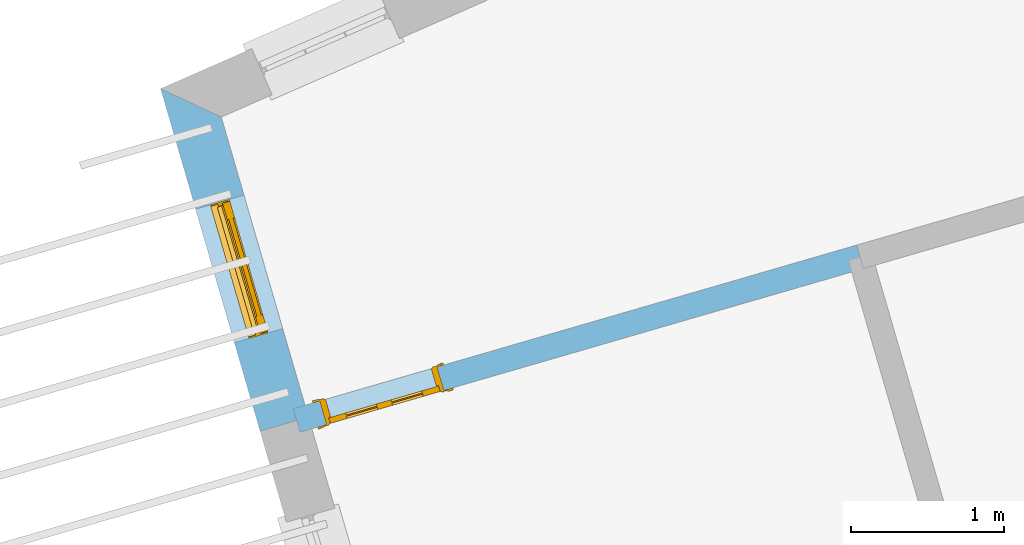
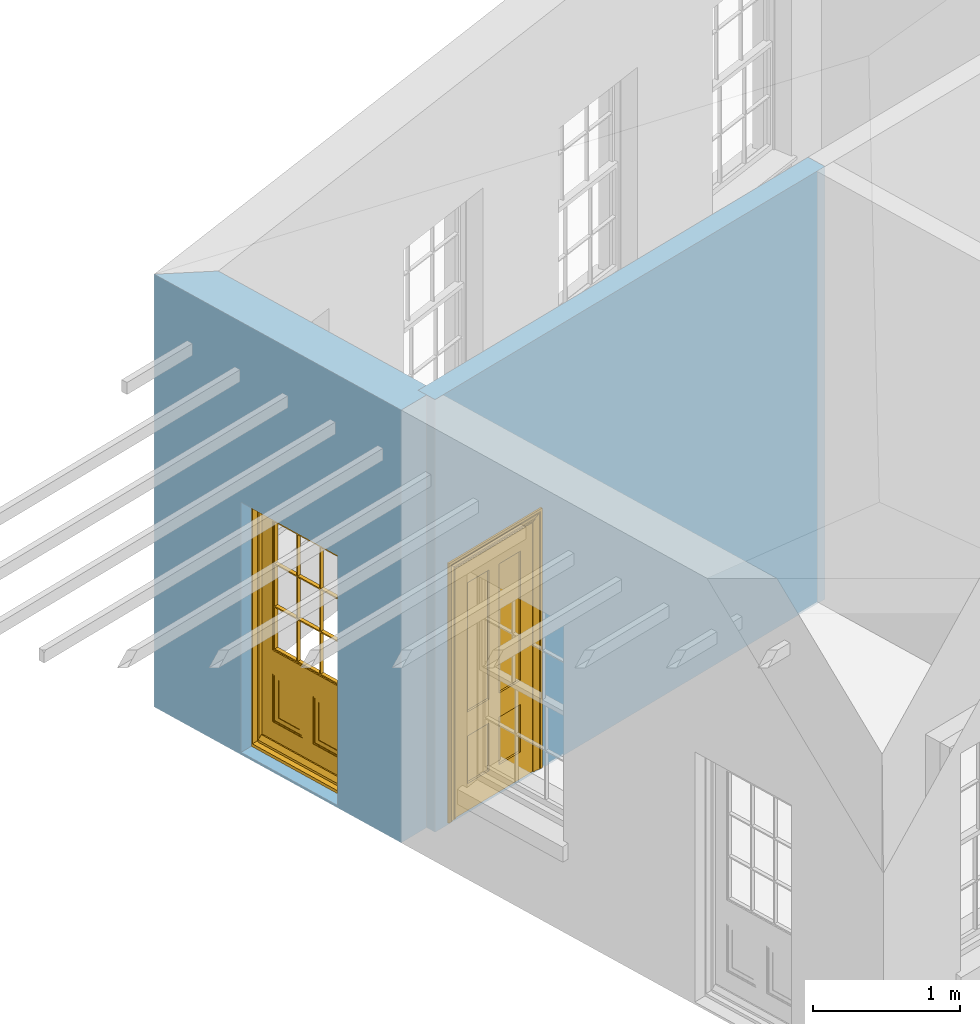
# One storey, part 4 of 10: 2 doors, 2 openings, plus 2 elements that do not belong to this part.
"""IFC2X3 building model written with IfcOpenShell, lengths in metres."""

import ifcopenshell
import ifcopenshell.guid

model = None  # the IFC model being written
_history = None  # IfcOwnerHistory: only IFC2X3 demands one
_inside = {}  # id of a spatial element -> (the spatial element, [elements in it])
_under = {}  # id of a project, library or spatial element -> (it, [spatial elements below it])
_declared = {}  # id of a project -> (the project, [libraries it declares])
_typed = {}  # id of a type object -> (the type object, [elements of that type])
_made_of = {}  # id of a material, layer set ... -> (it, [elements and type objects made of it])


def new_model(schema):
    """Start an empty IFC model of exactly this schema.

    Asked for "IFC4X3", IfcOpenShell would pick the latest addendum, in which some entities
    have other attributes; the version numbers below select the first issue.
    IFC2X3 requires an IfcOwnerHistory on every rooted entity: one is made here for all.
    """
    global model, _history
    if schema == "IFC4X3":
        model = ifcopenshell.file(schema_version=(4, 3, 0, 0))
    else:
        model = ifcopenshell.file(schema=schema)
    _inside.clear()
    _under.clear()
    _declared.clear()
    _typed.clear()
    _made_of.clear()
    _history = None
    if model.schema == "IFC2X3":
        org = make("IfcOrganization", Name="unknown")
        user = make(
            "IfcPersonAndOrganization",
            ThePerson=make("IfcPerson", FamilyName="unknown"),
            TheOrganization=org,
        )
        app = make(
            "IfcApplication",
            ApplicationDeveloper=org,
            Version="unknown",
            ApplicationFullName="unknown",
            ApplicationIdentifier="unknown",
        )
        _history = make(
            "IfcOwnerHistory",
            OwningUser=user,
            OwningApplication=app,
            ChangeAction="ADDED",
            CreationDate=0,
        )
    return model


def make(cls, **values):
    """One entity of the class cls with the attributes given. An attribute that is None is left unset."""
    return model.create_entity(
        cls, **{name: value for name, value in values.items() if value is not None}
    )


def rooted(cls, **values):
    """An entity with a GlobalId (a new one), such as an element, a storey or a relation."""
    return make(cls, GlobalId=ifcopenshell.guid.new(), OwnerHistory=_history, **values)


def si_unit(unit_type, name, prefix=None):
    """IfcSIUnit, for example si_unit("LENGTHUNIT", "METRE", prefix="MILLI")."""
    return make("IfcSIUnit", UnitType=unit_type, Prefix=prefix, Name=name)


def assignment(units):
    """IfcUnitAssignment: the units of a project."""
    return None if units is None else make("IfcUnitAssignment", Units=units)


def point(xyz):
    """IfcCartesianPoint."""
    return None if xyz is None else make("IfcCartesianPoint", Coordinates=xyz)


def direction(xyz):
    """IfcDirection."""
    return None if xyz is None else make("IfcDirection", DirectionRatios=xyz)


def frame(location, z_axis=None, x_axis=None):
    """IfcAxis2Placement3D, a coordinate frame: its origin and axes. An axis left out is left unset."""
    return make(
        "IfcAxis2Placement3D",
        Location=point(location),
        Axis=direction(z_axis),
        RefDirection=direction(x_axis),
    )


def origin():
    """The frame at (0, 0, 0) with its axes left unset."""
    return frame((0.0, 0.0, 0.0))


def place(relative_to, where):
    """IfcLocalPlacement: puts the frame where relative to a parent placement (None: the world)."""
    return make(
        "IfcLocalPlacement", PlacementRelTo=relative_to, RelativePlacement=where
    )


def context(
    kind, dimensions, precision=None, world=None, true_north=None, identifier=None
):
    """IfcGeometricRepresentationContext, for example the 3D "Model" context."""
    return make(
        "IfcGeometricRepresentationContext",
        ContextIdentifier=identifier,
        ContextType=kind,
        CoordinateSpaceDimension=dimensions,
        Precision=precision,
        WorldCoordinateSystem=world,
        TrueNorth=true_north,
    )


def subcontext(parent, identifier, kind, view, scale=None):
    """IfcGeometricRepresentationSubContext, for example "Body" below "Model"."""
    return make(
        "IfcGeometricRepresentationSubContext",
        ContextIdentifier=identifier,
        ContextType=kind,
        ParentContext=parent,
        TargetScale=scale,
        TargetView=view,
    )


def project(units=None, contexts=None):
    """IfcProject with its units and contexts."""
    return rooted(
        "IfcProject",
        Name="project",
        RepresentationContexts=contexts,
        UnitsInContext=assignment(units),
    )


def spatial(cls, under=None, at=None, **own):
    """A site, building, storey or space (cls), placed at a placement, below another one or the project."""
    s = rooted(cls, ObjectPlacement=at, **own)
    if under is not None:
        _under.setdefault(under.id(), (under, []))[1].append(s)
    return s


def polyline(points):
    """IfcPolyline through the points."""
    return make("IfcPolyline", Points=[point(p) for p in points])


def outline(outer, holes=None, kind="AREA"):
    """IfcArbitraryClosedProfileDef: a profile drawn as a closed curve; with holes, ...WithVoids."""
    if holes is None:
        return make("IfcArbitraryClosedProfileDef", ProfileType=kind, OuterCurve=outer)
    return make(
        "IfcArbitraryProfileDefWithVoids",
        ProfileType=kind,
        OuterCurve=outer,
        InnerCurves=holes,
    )


def extrude(swept, where, along, depth):
    """IfcExtrudedAreaSolid: the profile swept, set in the frame where, extruded along a direction by depth."""
    return make(
        "IfcExtrudedAreaSolid",
        SweptArea=swept,
        Position=where,
        ExtrudedDirection=direction(along),
        Depth=depth,
    )


def faces_of(points, faces, orient=None, outer=None):
    """IfcFace entities. A face is a list of loops; a loop is a list of indices into points, from 0.

    orient and outer hold one flag for each loop. By default every Orientation is true, the
    first loop of a face is its IfcFaceOuterBound and the others are IfcFaceBound.
    """
    made = []
    for i, loops in enumerate(faces):
        bounds = []
        for j, loop in enumerate(loops):
            is_outer = j == 0 if outer is None else outer[i][j]
            bounds.append(
                make(
                    "IfcFaceOuterBound" if is_outer else "IfcFaceBound",
                    Bound=make("IfcPolyLoop", Polygon=[points[k] for k in loop]),
                    Orientation=True if orient is None else orient[i][j],
                )
            )
        made.append(make("IfcFace", Bounds=bounds))
    return made


def faceted_brep(points, faces, orient=None, outer=None, voids=None):
    """IfcFacetedBrep: a solid bounded by flat faces; with voids (closed shells), ...WithVoids."""
    shared = [point(p) for p in points]
    hull = make("IfcClosedShell", CfsFaces=faces_of(shared, faces, orient, outer))
    if voids is None:
        return make("IfcFacetedBrep", Outer=hull)
    return make(
        "IfcFacetedBrepWithVoids",
        Outer=hull,
        Voids=[
            make(cls, CfsFaces=faces_of(shared, fs, o, b)) for cls, fs, o, b in voids
        ],
    )


def shape(context_of_items, identifier, shape_type, items):
    """IfcShapeRepresentation: the items that make up one representation, for example the "Body"."""
    return make(
        "IfcShapeRepresentation",
        ContextOfItems=context_of_items,
        RepresentationIdentifier=identifier,
        RepresentationType=shape_type,
        Items=items,
    )


def material(Name=None, Category=None):
    """IfcMaterial."""
    return make("IfcMaterial", Name=Name, Category=Category)


def layer(
    of_material, thickness, ventilated=None, Name=None, Category=None, Priority=None
):
    """IfcMaterialLayer: one layer of a wall or slab, of a material (None: an air gap)."""
    return make(
        "IfcMaterialLayer",
        Material=of_material,
        LayerThickness=thickness,
        IsVentilated=ventilated,
        Name=Name,
        Category=Category,
        Priority=Priority,
    )


def layer_set(layers, Name=None):
    """IfcMaterialLayerSet."""
    return make("IfcMaterialLayerSet", MaterialLayers=layers, LayerSetName=Name)


def layer_usage(for_layer_set, set_direction, sense, offset, extent=None):
    """IfcMaterialLayerSetUsage: how a layer set lies in its element."""
    return make(
        "IfcMaterialLayerSetUsage",
        ForLayerSet=for_layer_set,
        LayerSetDirection=set_direction,
        DirectionSense=sense,
        OffsetFromReferenceLine=offset,
        ReferenceExtent=extent,
    )


def made_of(thing, what):
    """Note that an element or type object is made of a material, layer set ...; save() writes the relation."""
    if what is not None:
        _made_of.setdefault(what.id(), (what, []))[1].append(thing)
    return thing


def element(
    cls,
    number,
    at=None,
    inside=None,
    cuts=None,
    type_object=None,
    material=None,
    context=None,
    identifier="Body",
    shape_type=None,
    held_by="IfcProductDefinitionShape",
    body=None,
    shapes=None,
    **own,
):
    """One element of the class cls, such as IfcWall. Its Tag is "e" and its number.

    at: its placement. inside: the storey or other place that contains it. cuts: it is an
    opening in that element (IfcRelVoidsElement). A single representation is given by context,
    identifier, shape_type and body (its items); several are given by shapes. held_by: the class
    of the entity that holds the representations. save() writes the other relations.
    """
    e = rooted(cls, Tag="e%d" % number, ObjectPlacement=at, **own)
    if body is not None:
        shapes = [shape(context, identifier, shape_type, body)]
    if shapes is not None:
        e.Representation = make(held_by, Representations=shapes)
    if inside is not None:
        _inside.setdefault(inside.id(), (inside, []))[1].append(e)
    if cuts is not None:
        rooted(
            "IfcRelVoidsElement", RelatingBuildingElement=cuts, RelatedOpeningElement=e
        )
    if type_object is not None:
        _typed.setdefault(type_object.id(), (type_object, []))[1].append(e)
    return made_of(e, material)


def fill(opening, filler):
    """IfcRelFillsElement: the door or window that sits in an opening."""
    return rooted(
        "IfcRelFillsElement",
        RelatingOpeningElement=opening,
        RelatedBuildingElement=filler,
    )


def aggregate(whole, parts):
    """IfcRelAggregates: a whole, such as a stair, and the parts it consists of."""
    return rooted("IfcRelAggregates", RelatingObject=whole, RelatedObjects=parts)


def save(model, path):
    """Write the relations noted so far, then the file.

    IfcRelAggregates (storeys below a building ...), IfcRelContainedInSpatialStructure (elements
    in a storey), IfcRelDefinesByType, IfcRelAssociatesMaterial and IfcRelDeclares: one each for
    every whole, place, type object, material and project.
    """
    for whole, parts in _under.values():
        aggregate(whole, parts)
    for where, things in _inside.values():
        rooted(
            "IfcRelContainedInSpatialStructure",
            RelatedElements=things,
            RelatingStructure=where,
        )
    for kind, things in _typed.values():
        rooted("IfcRelDefinesByType", RelatedObjects=things, RelatingType=kind)
    for what, things in _made_of.values():
        rooted("IfcRelAssociatesMaterial", RelatedObjects=things, RelatingMaterial=what)
    for by, libraries in _declared.values():
        rooted("IfcRelDeclares", RelatingContext=by, RelatedDefinitions=libraries)
    model.write(path)


model = new_model("IFC2X3")

# Units and contexts
model_context = context("Model", 3, world=origin())
body_context = subcontext(model_context, "Body", "Model", "MODEL_VIEW")
ifc_project = project(units=[si_unit("PLANEANGLEUNIT", "RADIAN"), si_unit("MASSUNIT", "GRAM", prefix="KILO"), si_unit("FORCEUNIT", "NEWTON", prefix="KILO"), si_unit("LENGTHUNIT", "METRE")], contexts=[model_context])

# Site, building, storey
site_placement = place(None, origin())
site = spatial("IfcSite", under=ifc_project, at=site_placement, CompositionType="ELEMENT")
building_placement = place(None, origin())
building = spatial("IfcBuilding", under=site, at=building_placement, Name="Building plot-15", CompositionType="ELEMENT")
storey_placement = place(None, frame((0.0, 0.0, 11.05)))
storey = spatial("IfcBuildingStorey", under=building, at=storey_placement, Name="Floor 2", CompositionType="ELEMENT", Elevation=11.05)

# Wall, opening, door
ifc_material_1 = material(Name="Masonry")
ifc_layer_1 = layer(ifc_material_1, 0.33, ventilated=False)
ifc_layer_set_1 = layer_set([ifc_layer_1], Name="My Wall")
ifc_layer_usage_1 = layer_usage(ifc_layer_set_1, "AXIS2", "NEGATIVE", 0.08)
wall_1_placement = place(storey_placement, origin())
wall_1 = element("IfcWallStandardCase", 1, at=wall_1_placement, inside=storey, material=ifc_layer_usage_1, Name="exterior", context=body_context, shape_type="SweptSolid", body=[
    extrude(outline(polyline([(89.0011789339124, 57.4790809319541), (88.6036069877965, 57.6648285454347), (89.2542381560141, 55.4242976754414), (89.5711465603263, 55.5163251891334), (89.0011789339124, 57.4790809319541)])), origin(), (0.0, 0.0, 1.0), 3.6),
])
opening_1_placement = place(storey_placement, frame((0.0, 0.0, 0.0199999999999996)))
opening_1 = element("IfcOpeningElement", 2, at=opening_1_placement, cuts=wall_1, Name="Opening", ObjectType="Opening", context=body_context, shape_type="SweptSolid", body=[
    extrude(outline(polyline([(88.8325905234072, 56.8762947257879), (89.0863633641941, 56.0023957926847), (89.4032717685063, 56.0944233063767), (89.1494989277193, 56.9683222394799), (88.8325905234072, 56.8762947257879)])), origin(), (0.0, 0.0, 1.0), 2.08),
])
door_1_placement = place(storey_placement, frame((89.0726726478861, 56.9460125391909, 0.0199999999999996), z_axis=(0.0, 0.0, 1.0), x_axis=(0.253772840786937, -0.873898933103206, 0.0)))
door_1 = element("IfcDoor", 3, at=door_1_placement, inside=storey, Name="circulation outside door", OverallHeight=2.08, OverallWidth=0.91, context=body_context, shape_type="Brep", held_by="IfcProductRepresentation", body=[
    faceted_brep([(0.545, -0.055, 0.265), (0.745, -0.055, 0.265), (0.745, -0.05, 0.265), (0.545, -0.05, 0.265), (0.745, -0.05, 0.58), (0.545, -0.05, 0.58), (0.545, -0.055, 0.58), (0.515, -0.06, 0.235), (0.775, -0.06, 0.235), (0.745, -0.055, 0.58), (0.515, -0.06, 0.61), (0.515, -0.065, 0.235), (0.775, -0.065, 0.235), (0.775, -0.06, 0.61), (0.515, -0.065, 0.61), (0.785, -0.065, 0.225), (0.505, -0.065, 0.225), (0.775, -0.065, 0.61), (0.505, -0.065, 0.62), (0.785, -0.065, 0.62), (0.505, -0.07, 0.225), (0.785, -0.07, 0.225), (0.505, -0.07, 0.62), (0.785, -0.07, 0.62), (0.883, -0.07, 0.075), (0.898, -0.07, 0.075), (0.405, -0.07, 0.62), (0.405, -0.07, 0.225), (0.027, -0.07, 0.075), (0.785, -0.07, 0.82), (0.125, -0.07, 0.82), (0.405, -0.065, 0.62), (0.405, -0.065, 0.225), (0.898, -0.07, 2.068), (0.027, -0.08, 0.075), (0.883, -0.08, 0.075), (0.125, -0.07, 0.225), (0.012, -0.07, 0.075), (0.785, -0.06, 0.82), (0.125, -0.06, 0.82), (0.125, -0.07, 0.62), (0.125, -0.065, 0.62), (0.395, -0.065, 0.61), (0.395, -0.065, 0.235), (0.125, -0.065, 0.225), (0.785, -0.07, 1.895), (0.027, -0.11, 0.045), (0.883, -0.11, 0.045), (0.558333, -0.06, 0.83), (0.351667, -0.06, 0.83), (0.125, -0.07, 1.895), (0.125, -0.06, 1.895), (0.785, -0.06, 1.895), (0.012, -0.07, 2.068), (0.135, -0.065, 0.61), (0.395, -0.06, 0.61), (0.395, -0.06, 0.235), (0.135, -0.065, 0.235), (0.027, -0.11, 0.027), (0.883, -0.11, 0.027), (0.568333, -0.06, 0.83), (0.558333, -0.03, 0.83), (0.351667, -0.03, 0.83), (0.341667, -0.06, 0.83), (0.135, -0.06, 1.185), (0.135, -0.06, 1.53), (0.775, -0.06, 1.53), (0.775, -0.06, 1.185), (0.135, -0.06, 0.61), (0.365, -0.055, 0.58), (0.365, -0.055, 0.265), (0.135, -0.06, 0.235), (0.568333, -0.06, 1.175), (0.558333, -0.06, 1.175), (0.775, -0.06, 0.83), (0.558333, -0.03, 1.175), (0.785, -0.03, 0.82), (0.125, -0.03, 0.82), (0.351667, -0.03, 1.175), (0.351667, -0.06, 1.175), (0.341667, -0.06, 1.175), (0.135, -0.06, 0.83), (0.135, -0.06, 1.175), (0.135, -0.03, 1.185), (0.135, -0.03, 1.53), (0.135, -0.06, 1.54), (0.351667, -0.06, 1.885), (0.558333, -0.06, 1.885), (0.775, -0.03, 1.53), (0.775, -0.03, 1.185), (0.775, -0.06, 1.175), (0.775, -0.06, 1.54), (0.165, -0.055, 0.58), (0.365, -0.05, 0.58), (0.365, -0.05, 0.265), (0.165, -0.055, 0.265), (0.568333, -0.03, 0.83), (0.568333, -0.03, 1.175), (0.568333, -0.06, 1.185), (0.558333, -0.06, 1.185), (0.775, -0.03, 0.83), (0.785, -0.02, 0.82), (0.125, -0.02, 0.82), (0.341667, -0.03, 0.83), (0.341667, -0.03, 1.175), (0.351667, -0.06, 1.185), (0.341667, -0.06, 1.185), (0.135, -0.03, 0.83), (0.341667, -0.03, 1.185), (0.125, -0.03, 1.895), (0.341667, -0.03, 1.53), (0.341667, -0.06, 1.53), (0.135, -0.06, 1.885), (0.341667, -0.06, 1.54), (0.341667, -0.06, 1.885), (0.558333, -0.03, 1.885), (0.351667, -0.03, 1.885), (0.568333, -0.06, 1.885), (0.785, -0.03, 1.895), (0.568333, -0.03, 1.185), (0.568333, -0.06, 1.53), (0.568333, -0.03, 1.53), (0.568333, -0.06, 1.54), (0.775, -0.06, 1.885), (0.165, -0.05, 0.58), (0.165, -0.05, 0.265), (0.775, -0.03, 1.175), (0.558333, -0.06, 1.53), (0.351667, -0.03, 1.185), (0.558333, -0.03, 1.185), (0.505, -0.02, 0.62), (0.405, -0.02, 0.62), (0.125, -0.02, 1.895), (0.785, -0.02, 1.895), (0.351667, -0.06, 1.53), (0.135, -0.03, 1.175), (0.135, -0.03, 1.54), (0.341667, -0.03, 1.54), (0.135, -0.03, 1.885), (0.351667, -0.06, 1.54), (0.558333, -0.03, 1.54), (0.558333, -0.06, 1.54), (0.351667, -0.03, 1.54), (0.775, -0.03, 1.54), (0.568333, -0.03, 1.54), (0.775, -0.03, 1.885), (0.558333, -0.03, 1.53), (0.405, -0.02, 0.225), (0.505, -0.02, 0.225), (0.125, -0.02, 0.62), (0.785, -0.02, 0.62), (0.012, -0.02, 2.068), (0.898, -0.02, 2.068), (0.351667, -0.03, 1.53), (0.341667, -0.03, 1.885), (0.568333, -0.03, 1.885), (0.405, -0.025, 0.225), (0.405, -0.025, 0.62), (0.505, -0.025, 0.62), (0.505, -0.025, 0.225), (0.898, -0.02, 0.027), (0.012, -0.02, 0.027), (0.125, -0.025, 0.62), (0.785, -0.025, 0.62), (0.395, -0.025, 0.235), (0.395, -0.025, 0.61), (0.125, -0.02, 0.225), (0.125, -0.025, 0.225), (0.515, -0.025, 0.61), (0.515, -0.025, 0.235), (0.785, -0.02, 0.225), (0.785, -0.025, 0.225), (0.135, -0.025, 0.61), (0.775, -0.025, 0.61), (0.135, -0.025, 0.235), (0.395, -0.03, 0.235), (0.395, -0.03, 0.61), (0.515, -0.03, 0.61), (0.515, -0.03, 0.235), (0.775, -0.025, 0.235), (0.135, -0.03, 0.61), (0.775, -0.03, 0.61), (0.135, -0.03, 0.235), (0.365, -0.035, 0.265), (0.365, -0.035, 0.58), (0.545, -0.035, 0.58), (0.545, -0.035, 0.265), (0.775, -0.03, 0.235), (0.165, -0.035, 0.58), (0.745, -0.035, 0.58), (0.165, -0.035, 0.265), (0.365, -0.04, 0.58), (0.365, -0.04, 0.265), (0.545, -0.04, 0.58), (0.545, -0.04, 0.265), (0.745, -0.035, 0.265), (0.165, -0.04, 0.58), (0.745, -0.04, 0.58), (0.165, -0.04, 0.265), (0.745, -0.04, 0.265), (0.885, -0.072, 0.025), (0.025, -0.072, 0.025), (0.025, -0.1, 0.025), (0.885, -0.1, 0.025), (0.9, -0.02, 0.025), (0.01, -0.02, 0.025), (0.9, -0.072, 0.025), (0.91, -0.02, 0.0), (0.0, -0.02, 0.0), (0.01, -0.072, 0.025), (0.9, -0.072, 2.07), (0.9, -0.02, 2.07), (0.885, -0.072, 2.055), (0.91, -0.02, 2.08), (0.01, -0.02, 2.07), (0.0, -0.02, 2.08), (0.01, -0.072, 2.07), (0.025, -0.072, 2.055), (0.0, -0.15, 2.08), (0.91, -0.15, 2.08), (0.01, -0.15, 2.07), (0.9, -0.15, 2.07), (0.01, -0.1, 2.07), (0.9, -0.1, 2.07), (0.0, -0.15, 0.0), (0.91, -0.15, 0.0), (0.01, -0.15, 0.025), (0.9, -0.15, 0.025), (0.01, -0.1, 0.025), (0.025, -0.1, 2.055), (0.9, -0.1, 0.025), (0.885, -0.1, 2.055), (0.898, -0.07, 0.027), (0.012, -0.07, 0.027), (0.883, -0.07, 0.027), (0.027, -0.07, 0.027)], [[[0, 1, 2, 3]], [[2, 4, 5, 3]], [[0, 3, 5, 6]], [[1, 0, 7, 8]], [[9, 4, 2, 1]], [[9, 6, 5, 4]], [[0, 6, 10, 7]], [[8, 7, 11, 12]], [[8, 13, 9, 1]], [[13, 10, 6, 9]], [[7, 10, 14, 11]], [[15, 12, 11, 16]], [[12, 17, 13, 8]], [[17, 14, 10, 13]], [[18, 16, 11, 14]], [[15, 19, 17, 12]], [[15, 16, 20, 21]], [[14, 17, 19, 18]], [[16, 18, 22, 20]], [[21, 23, 19, 15]], [[24, 25, 21, 20]], [[23, 22, 18, 19]], [[20, 22, 26, 27]], [[23, 21, 25]], [[28, 24, 20, 27]], [[22, 23, 29]], [[29, 30, 26, 22]], [[27, 26, 31, 32]], [[23, 25, 33, 29]], [[34, 35, 24, 28]], [[28, 27, 36, 37]], [[38, 39, 30, 29]], [[26, 30, 40]], [[26, 40, 41, 31]], [[42, 43, 32, 31]], [[32, 44, 36, 27]], [[33, 45, 29]], [[46, 47, 35, 34]], [[36, 40, 37]], [[39, 38, 48, 49]], [[50, 30, 39, 51]], [[29, 45, 52, 38]], [[53, 37, 40, 30]], [[44, 41, 40, 36]], [[31, 41, 54, 42]], [[43, 42, 55, 56]], [[57, 44, 32, 43]], [[50, 45, 33, 53]], [[47, 46, 58, 59]], [[60, 48, 38]], [[49, 48, 61, 62]], [[49, 63, 39]], [[50, 53, 30]], [[51, 39, 64, 65]], [[45, 50, 51, 52]], [[66, 67, 38, 52]], [[57, 54, 41, 44]], [[42, 54, 68, 55]], [[56, 55, 69, 70]], [[56, 71, 57, 43]], [[60, 72, 73, 48]], [[60, 38, 74]], [[48, 73, 75, 61]], [[76, 77, 62, 61]], [[62, 78, 79, 49]], [[49, 79, 80, 63]], [[63, 81, 39]], [[82, 64, 39]], [[65, 64, 83, 84]], [[85, 51, 65]], [[52, 51, 86, 87]], [[88, 89, 67, 66]], [[90, 38, 67]], [[91, 66, 52]], [[71, 68, 54, 57]], [[55, 68, 92, 69]], [[69, 93, 94, 70]], [[70, 95, 71, 56]], [[96, 97, 72, 60]], [[73, 72, 98, 99]], [[74, 38, 90]], [[100, 96, 60, 74]], [[75, 73, 79, 78]], [[61, 75, 97, 96]], [[101, 102, 77, 76]], [[77, 103, 62]], [[96, 76, 61]], [[103, 104, 78, 62]], [[80, 79, 105, 106]], [[63, 80, 104, 103]], [[81, 63, 103, 107]], [[81, 82, 39]], [[106, 64, 82, 80]], [[106, 108, 83, 64]], [[84, 83, 77, 109]], [[110, 111, 65, 84]], [[112, 51, 85]], [[113, 85, 65, 111]], [[114, 86, 51]], [[115, 87, 86, 116]], [[117, 52, 87]], [[118, 76, 89, 88]], [[119, 98, 67, 89]], [[120, 121, 88, 66]], [[67, 98, 72, 90]], [[91, 122, 120, 66]], [[91, 52, 123]], [[95, 92, 68, 71]], [[69, 92, 124, 93]], [[94, 93, 124, 125]], [[94, 125, 95, 70]], [[72, 97, 126, 90]], [[127, 99, 98, 120]], [[99, 105, 79, 73]], [[74, 90, 126, 100]], [[96, 100, 76]], [[128, 129, 75, 78]], [[97, 75, 129, 119]], [[130, 131, 102, 101]], [[109, 77, 102, 132]], [[133, 101, 76, 118]], [[77, 107, 103]], [[78, 104, 108, 128]], [[111, 106, 105, 134]], [[104, 80, 82, 135]], [[107, 135, 82, 81]], [[110, 108, 106, 111]], [[104, 135, 83, 108]], [[83, 135, 77]], [[136, 84, 109]], [[110, 84, 136, 137]], [[114, 51, 112]], [[85, 136, 138, 112]], [[113, 137, 136, 85]], [[111, 134, 139, 113]], [[86, 114, 113, 139]], [[140, 141, 87, 115]], [[139, 142, 116, 86]], [[109, 118, 115, 116]], [[117, 123, 52]], [[117, 87, 141, 122]], [[126, 89, 76]], [[143, 118, 88]], [[120, 98, 119, 121]], [[119, 89, 126, 97]], [[144, 143, 88, 121]], [[144, 122, 91, 143]], [[127, 120, 122, 141]], [[143, 91, 123, 145]], [[124, 92, 95, 125]], [[146, 129, 99, 127]], [[99, 129, 128, 105]], [[100, 126, 76]], [[121, 119, 129, 146]], [[147, 131, 130, 148]], [[131, 149, 102]], [[130, 101, 150]], [[102, 151, 132]], [[118, 109, 132, 133]], [[101, 133, 152]], [[107, 77, 135]], [[153, 128, 108, 110]], [[134, 105, 128, 153]], [[109, 138, 136]], [[153, 110, 137, 142]], [[154, 114, 112, 138]], [[137, 113, 114, 154]], [[141, 139, 134, 127]], [[141, 140, 142, 139]], [[144, 140, 115, 155]], [[142, 137, 154, 116]], [[155, 115, 118]], [[116, 154, 109]], [[117, 155, 145, 123]], [[122, 144, 155, 117]], [[143, 145, 118]], [[121, 146, 140, 144]], [[146, 127, 134, 153]], [[156, 157, 131, 147]], [[148, 130, 158, 159]], [[148, 160, 161, 147]], [[157, 162, 149, 131]], [[161, 151, 102, 149]], [[101, 152, 160, 150]], [[163, 158, 130, 150]], [[151, 152, 133, 132]], [[154, 138, 109]], [[142, 140, 146, 153]], [[145, 155, 118]], [[157, 156, 164, 165]], [[147, 166, 167, 156]], [[168, 169, 159, 158]], [[170, 148, 159, 171]], [[148, 170, 160]], [[166, 147, 161]], [[172, 162, 157, 165]], [[166, 149, 162, 167]], [[166, 161, 149]], [[150, 160, 170]], [[163, 173, 168, 158]], [[171, 163, 150, 170]], [[174, 164, 156, 167]], [[175, 176, 165, 164]], [[169, 168, 177, 178]], [[171, 159, 169, 179]], [[167, 162, 172, 174]], [[176, 180, 172, 165]], [[179, 173, 163, 171]], [[181, 177, 168, 173]], [[164, 174, 182, 175]], [[183, 184, 176, 175]], [[178, 177, 185, 186]], [[179, 169, 178, 187]], [[174, 172, 180, 182]], [[184, 188, 180, 176]], [[187, 181, 173, 179]], [[189, 185, 177, 181]], [[175, 182, 190, 183]], [[191, 184, 183, 192]], [[185, 193, 194, 186]], [[187, 178, 186, 195]], [[182, 180, 188, 190]], [[191, 196, 188, 184]], [[195, 189, 181, 187]], [[197, 193, 185, 189]], [[183, 190, 198, 192]], [[198, 196, 191, 192]], [[194, 193, 197, 199]], [[195, 186, 194, 199]], [[188, 196, 198, 190]], [[197, 189, 195, 199]], [[200, 201, 202, 203]], [[201, 200, 204, 205]], [[206, 204, 200]], [[204, 207, 208, 205]], [[209, 201, 205]], [[210, 211, 204, 206]], [[206, 200, 212, 210]], [[211, 213, 207, 204]], [[214, 205, 208, 215]], [[216, 217, 201, 209]], [[205, 214, 216, 209]], [[216, 214, 211, 210]], [[210, 212, 217, 216]], [[214, 215, 213, 211]], [[218, 219, 213, 215]], [[219, 218, 220, 221]], [[221, 220, 222, 223]], [[215, 208, 224, 218]], [[225, 224, 208, 207]], [[224, 226, 220, 218]], [[224, 225, 227, 226]], [[219, 225, 207, 213]], [[228, 222, 220, 226]], [[219, 221, 227, 225]], [[226, 227, 203, 202]], [[202, 229, 222, 228]], [[228, 226, 202]], [[227, 221, 223, 230]], [[230, 203, 227]], [[217, 229, 202, 201]], [[231, 223, 222, 229]], [[230, 223, 231, 203]], [[231, 229, 217, 212]], [[212, 200, 203, 231]], [[33, 152, 151, 53]], [[25, 160, 152, 33]], [[161, 37, 53, 151]], [[232, 160, 25]], [[161, 233, 37]], [[160, 232, 234]], [[24, 234, 232, 25]], [[233, 161, 235]], [[37, 233, 235, 28]], [[161, 160, 234, 235]], [[35, 47, 234, 24]], [[28, 235, 46, 34]], [[58, 235, 234, 59]], [[59, 234, 47]], [[58, 46, 235]]]),
])
fill(opening_1, door_1)

ifc_material_2 = material(Name="Masonry")
ifc_layer_2 = layer(ifc_material_2, 0.16, ventilated=False)
ifc_layer_set_2 = layer_set([ifc_layer_2], Name="My Wall")
ifc_layer_usage_2 = layer_usage(ifc_layer_set_2, "AXIS2", "NEGATIVE", 0.08)
wall_2_placement = place(storey_placement, origin())
wall_2 = element("IfcWallStandardCase", 4, at=wall_2_placement, inside=storey, material=ifc_layer_usage_2, Name="interior", context=body_context, shape_type="SweptSolid", body=[
    extrude(outline(polyline([(93.2027716667049, 56.4876135015068), (93.1581522661269, 56.6412660611732), (89.472010580204, 55.5708417686776), (89.516629980782, 55.4171892090111), (93.2027716667049, 56.4876135015068)])), origin(), (0.0, 0.0, 1.0), 3.6),
])
opening_2_placement = place(storey_placement, frame((0.0, 0.0, 0.0199999999999996)))
opening_2 = element("IfcOpeningElement", 5, at=opening_2_placement, cuts=wall_2, Name="Opening", ObjectType="Opening", context=body_context, shape_type="SweptSolid", body=[
    extrude(outline(polyline([(90.4131325081614, 55.8441355972174), (89.6448697098289, 55.6210385943278), (89.6894891104068, 55.4673860346613), (90.4577519087393, 55.6904830375509), (90.4131325081614, 55.8441355972174)])), origin(), (0.0, 0.0, 1.0), 2.1),
])
door_2_placement = place(storey_placement, frame((90.4354422084503, 55.7673093173841, 0.0199999999999996), z_axis=(0.0, 0.0, 1.0), x_axis=(-0.768262798332501, -0.223097002889588, 0.0)))
door_2 = element("IfcDoor", 6, at=door_2_placement, inside=storey, Name="bedroom inside door", OverallHeight=2.1, OverallWidth=0.8, context=body_context, shape_type="Brep", held_by="IfcProductRepresentation", body=[
    faceted_brep([(0.773, 0.08, 1.895), (0.66, 0.08, 1.895), (0.66, 0.08, 2.073), (0.773, 0.08, 2.073), (0.773, 0.08, 0.82), (0.66, 0.08, 0.82), (0.45, 0.08, 1.895), (0.45, 0.08, 2.073), (0.773, 0.08, 0.62), (0.66, 0.08, 0.62), (0.66, 0.065, 0.82), (0.66, 0.065, 1.895), (0.45, 0.065, 1.895), (0.35, 0.08, 1.895), (0.35, 0.08, 2.073), (0.773, 0.08, 0.225), (0.66, 0.08, 0.225), (0.45, 0.08, 0.62), (0.45, 0.08, 0.82), (0.45, 0.065, 0.82), (0.35, 0.08, 0.82), (0.14, 0.08, 2.073), (0.14, 0.08, 1.895), (0.773, 0.08, 0.0), (0.66, 0.08, 0.0), (0.66, 0.065, 0.225), (0.66, 0.065, 0.62), (0.45, 0.065, 0.62), (0.35, 0.08, 0.62), (0.35, 0.065, 0.82), (0.35, 0.065, 1.895), (0.14, 0.065, 1.895), (0.027, 0.08, 2.073), (0.027, 0.08, 1.895), (0.773, 0.042, 0.0), (0.66, 0.042, 0.0), (0.45, 0.08, 0.0), (0.45, 0.08, 0.225), (0.45, 0.065, 0.225), (0.35, 0.08, 0.225), (0.14, 0.08, 0.82), (0.14, 0.08, 0.62), (0.14, 0.065, 0.82), (0.027, 0.08, 0.82), (0.773, 0.042, 0.225), (0.66, 0.042, 0.225), (0.45, 0.042, 0.0), (0.35, 0.08, 0.0), (0.35, 0.065, 0.225), (0.35, 0.065, 0.62), (0.14, 0.065, 0.62), (0.027, 0.08, 0.62), (0.773, 0.042, 0.62), (0.66, 0.042, 0.62), (0.45, 0.042, 0.225), (0.35, 0.042, 0.0), (0.14, 0.08, 0.225), (0.14, 0.08, 0.0), (0.14, 0.065, 0.225), (0.027, 0.08, 0.225), (0.773, 0.042, 0.82), (0.66, 0.042, 0.82), (0.66, 0.057, 0.62), (0.66, 0.057, 0.225), (0.45, 0.057, 0.225), (0.35, 0.042, 0.225), (0.14, 0.042, 0.0), (0.027, 0.08, 0.0), (0.773, 0.042, 1.895), (0.66, 0.042, 1.895), (0.45, 0.042, 0.62), (0.45, 0.042, 0.82), (0.45, 0.057, 0.62), (0.35, 0.042, 0.62), (0.14, 0.042, 0.225), (0.027, 0.042, 0.0), (0.773, 0.042, 2.073), (0.66, 0.042, 2.073), (0.66, 0.057, 1.895), (0.66, 0.057, 0.82), (0.45, 0.057, 0.82), (0.35, 0.042, 0.82), (0.35, 0.057, 0.62), (0.35, 0.057, 0.225), (0.14, 0.057, 0.225), (0.027, 0.042, 0.225), (0.45, 0.042, 1.895), (0.45, 0.042, 2.073), (0.45, 0.057, 1.895), (0.35, 0.042, 1.895), (0.14, 0.042, 0.82), (0.14, 0.042, 0.62), (0.14, 0.057, 0.62), (0.027, 0.042, 0.62), (0.35, 0.042, 2.073), (0.35, 0.057, 1.895), (0.35, 0.057, 0.82), (0.14, 0.057, 0.82), (0.027, 0.042, 0.82), (0.14, 0.042, 2.073), (0.14, 0.042, 1.895), (0.14, 0.057, 1.895), (0.027, 0.042, 1.895), (0.027, 0.042, 2.073), (0.02, 0.085, 0.0), (0.005, 0.09, 0.0), (0.005, 0.09, 2.095), (0.02, 0.085, 2.08), (0.02, 0.08, 0.0), (0.0, 0.085, 0.0), (0.0, 0.085, 2.1), (0.795, 0.09, 2.095), (0.78, 0.085, 2.08), (0.02, 0.08, 2.08), (0.0, 0.08, 0.0), (-0.032, 0.095, 0.0), (-0.032, 0.095, 2.132), (0.8, 0.085, 2.1), (0.795, 0.09, 0.0), (0.78, 0.085, 0.0), (0.78, 0.08, 2.08), (0.04, 0.04, 0.0), (0.025, 0.04, 0.0), (0.025, 0.04, 2.075), (0.04, 0.04, 2.06), (-0.04, 0.09, 0.0), (-0.04, 0.09, 2.14), (0.832, 0.095, 2.132), (0.8, 0.085, 0.0), (0.78, 0.08, 0.0), (0.8, 0.08, 0.0), (0.86, 0.08, 0.0), (0.86, 0.08, 2.16), (0.8, 0.08, 2.1), (-0.06, 0.08, 2.16), (0.0, 0.08, 2.1), (-0.06, 0.08, 0.0), (-0.04, 0.095, 0.0), (-0.04, 0.095, 2.14), (0.84, 0.09, 2.14), (0.832, 0.095, 0.0), (0.84, 0.09, 0.0), (0.86, 0.095, 0.0), (0.86, 0.095, 2.16), (-0.06, 0.095, 2.16), (-0.06, 0.095, 0.0), (0.84, 0.095, 0.0), (0.84, 0.095, 2.14), (-0.025, -0.095, 0.0), (-0.025, -0.09, 0.0), (-0.025, -0.09, 2.125), (-0.025, -0.095, 2.125), (-0.017, -0.095, 0.0), (-0.017, -0.095, 2.117), (0.825, -0.09, 2.125), (0.825, -0.095, 2.125), (0.825, -0.095, 0.0), (0.845, -0.095, 0.0), (-0.045, -0.095, 2.145), (-0.045, -0.095, 0.0), (0.845, -0.095, 2.145), (0.015, -0.085, 0.0), (0.015, -0.085, 2.085), (0.817, -0.095, 2.117), (0.825, -0.09, 0.0), (0.845, -0.08, 0.0), (0.845, -0.08, 2.145), (-0.045, -0.08, 2.145), (-0.045, -0.08, 0.0), (0.02, -0.09, 0.0), (0.02, -0.09, 2.08), (0.785, -0.085, 2.085), (0.817, -0.095, 0.0), (0.8, -0.08, 0.0), (0.8, -0.08, 2.1), (0.0, -0.08, 2.1), (0.0, -0.08, 0.0), (0.035, -0.085, 0.0), (0.035, -0.085, 2.065), (0.78, -0.09, 2.08), (0.785, -0.085, 0.0), (0.775, 0.04, 2.075), (0.76, 0.04, 2.06), (0.035, -0.08, 2.065), (0.035, -0.08, 0.0), (0.765, -0.085, 2.065), (0.78, -0.09, 0.0), (0.765, -0.08, 0.0), (0.765, -0.08, 2.065), (0.765, -0.085, 0.0), (0.04, -0.08, 2.06), (0.04, -0.08, 0.0), (0.76, -0.08, 2.06), (0.76, -0.08, 0.0), (0.76, 0.04, 0.0), (0.775, 0.04, 0.0), (0.025, 0.08, 0.0), (0.025, 0.08, 2.075), (0.775, 0.08, 0.0), (0.775, 0.08, 2.075)], [[[0, 1, 2, 3]], [[1, 0, 4, 5]], [[1, 6, 7, 2]], [[8, 9, 5, 4]], [[1, 5, 10, 11]], [[6, 1, 11, 12]], [[6, 13, 14, 7]], [[15, 16, 9, 8]], [[9, 17, 18, 5]], [[5, 18, 19, 10]], [[10, 19, 12, 11]], [[18, 6, 12, 19]], [[18, 20, 13, 6]], [[21, 14, 13, 22]], [[23, 24, 16, 15]], [[9, 16, 25, 26]], [[17, 9, 26, 27]], [[17, 28, 20, 18]], [[13, 20, 29, 30]], [[22, 13, 30, 31]], [[32, 21, 22, 33]], [[34, 35, 24, 23]], [[24, 36, 37, 16]], [[16, 37, 38, 25]], [[25, 38, 27, 26]], [[37, 17, 27, 38]], [[37, 39, 28, 17]], [[40, 20, 28, 41]], [[20, 40, 42, 29]], [[31, 30, 29, 42]], [[40, 22, 31, 42]], [[33, 22, 40, 43]], [[35, 34, 44, 45]], [[35, 46, 36, 24]], [[36, 47, 39, 37]], [[28, 39, 48, 49]], [[41, 28, 49, 50]], [[43, 40, 41, 51]], [[45, 44, 52, 53]], [[46, 35, 45, 54]], [[46, 55, 47, 36]], [[56, 39, 47, 57]], [[39, 56, 58, 48]], [[50, 49, 48, 58]], [[56, 41, 50, 58]], [[51, 41, 56, 59]], [[53, 52, 60, 61]], [[45, 53, 62, 63]], [[54, 45, 63, 64]], [[55, 46, 54, 65]], [[55, 66, 57, 47]], [[59, 56, 57, 67]], [[61, 60, 68, 69]], [[70, 53, 61, 71]], [[53, 70, 72, 62]], [[72, 64, 63, 62]], [[70, 54, 64, 72]], [[65, 54, 70, 73]], [[65, 74, 66, 55]], [[67, 57, 66, 75]], [[69, 68, 76, 77]], [[61, 69, 78, 79]], [[71, 61, 79, 80]], [[73, 70, 71, 81]], [[65, 73, 82, 83]], [[74, 65, 83, 84]], [[74, 85, 75, 66]], [[86, 69, 77, 87]], [[69, 86, 88, 78]], [[88, 80, 79, 78]], [[86, 71, 80, 88]], [[81, 71, 86, 89]], [[73, 81, 90, 91]], [[73, 91, 92, 82]], [[83, 82, 92, 84]], [[91, 74, 84, 92]], [[91, 93, 85, 74]], [[89, 86, 87, 94]], [[81, 89, 95, 96]], [[90, 81, 96, 97]], [[90, 98, 93, 91]], [[94, 99, 100, 89]], [[89, 100, 101, 95]], [[101, 97, 96, 95]], [[100, 90, 97, 101]], [[100, 102, 98, 90]], [[99, 103, 102, 100]], [[32, 103, 99, 21]], [[102, 103, 32, 33]], [[98, 102, 33, 43]], [[21, 99, 94, 14]], [[94, 87, 7, 14]], [[7, 87, 77, 2]], [[76, 3, 2, 77]], [[43, 51, 93, 98]], [[51, 59, 85, 93]], [[67, 75, 85, 59]], [[34, 23, 15, 44]], [[44, 15, 8, 52]], [[52, 8, 4, 60]], [[0, 68, 60, 4]], [[0, 3, 76, 68]], [[104, 105, 106, 107]], [[104, 108, 109, 105]], [[105, 109, 110, 106]], [[107, 106, 111, 112]], [[107, 113, 108, 104]], [[114, 109, 108]], [[109, 115, 116, 110]], [[106, 110, 117, 111]], [[112, 111, 118, 119]], [[113, 107, 112, 120]], [[121, 122, 123, 124]], [[115, 109, 114, 125]], [[115, 125, 126, 116]], [[110, 116, 127, 117]], [[111, 117, 128, 118]], [[118, 128, 129, 119]], [[120, 112, 119, 129]], [[130, 129, 128]], [[130, 131, 132, 133]], [[133, 132, 134, 135]], [[135, 134, 136, 114]], [[136, 125, 114]], [[125, 137, 138, 126]], [[116, 126, 139, 127]], [[117, 127, 140, 128]], [[141, 130, 128, 140]], [[131, 130, 141]], [[131, 142, 143, 132]], [[132, 143, 144, 134]], [[134, 144, 145, 136]], [[137, 125, 136, 145]], [[143, 142, 146]], [[143, 146, 147]], [[137, 145, 144]], [[143, 147, 138]], [[138, 137, 144]], [[143, 138, 144]], [[126, 138, 147, 139]], [[127, 139, 141, 140]], [[142, 131, 141, 146]], [[139, 147, 146, 141]], [[148, 149, 150, 151]], [[149, 152, 153, 150]], [[151, 150, 154, 155]], [[155, 156, 157]], [[158, 159, 148]], [[158, 148, 151]], [[155, 157, 160]], [[158, 151, 155]], [[155, 160, 158]], [[152, 161, 162, 153]], [[150, 153, 163, 154]], [[155, 154, 164, 156]], [[156, 164, 165, 157]], [[157, 165, 166, 160]], [[160, 166, 167, 158]], [[158, 167, 168, 159]], [[161, 169, 170, 162]], [[153, 162, 171, 163]], [[154, 163, 172, 164]], [[165, 164, 173]], [[165, 173, 174, 166]], [[166, 174, 175, 167]], [[167, 175, 176, 168]], [[169, 177, 178, 170]], [[162, 170, 179, 171]], [[163, 171, 180, 172]], [[172, 180, 173, 164]], [[124, 123, 181, 182]], [[183, 178, 177, 184]], [[170, 178, 185, 179]], [[171, 179, 186, 180]], [[187, 173, 180]], [[185, 188, 187, 189]], [[188, 185, 178, 183]], [[179, 185, 189, 186]], [[189, 187, 180, 186]], [[190, 183, 184, 191]], [[192, 188, 183, 190]], [[191, 184, 122, 121]], [[124, 190, 191, 121]], [[193, 187, 188, 192]], [[182, 192, 190, 124]], [[184, 176, 122]], [[194, 195, 187, 193]], [[192, 182, 194, 193]], [[161, 176, 184]], [[114, 108, 122, 176]], [[173, 187, 195]], [[152, 149, 176, 161]], [[169, 161, 184, 177]], [[196, 122, 108]], [[176, 175, 135, 114]], [[173, 195, 129, 130]], [[176, 149, 168]], [[123, 122, 196, 197]], [[196, 108, 113, 197]], [[175, 174, 133, 135]], [[198, 129, 195]], [[133, 174, 173, 130]], [[159, 168, 149, 148]], [[181, 123, 197, 199]], [[197, 113, 120, 199]], [[199, 120, 129, 198]], [[195, 181, 199, 198]], [[195, 194, 182, 181]]]),
])
fill(opening_2, door_2)

save(model, "model.ifc")
